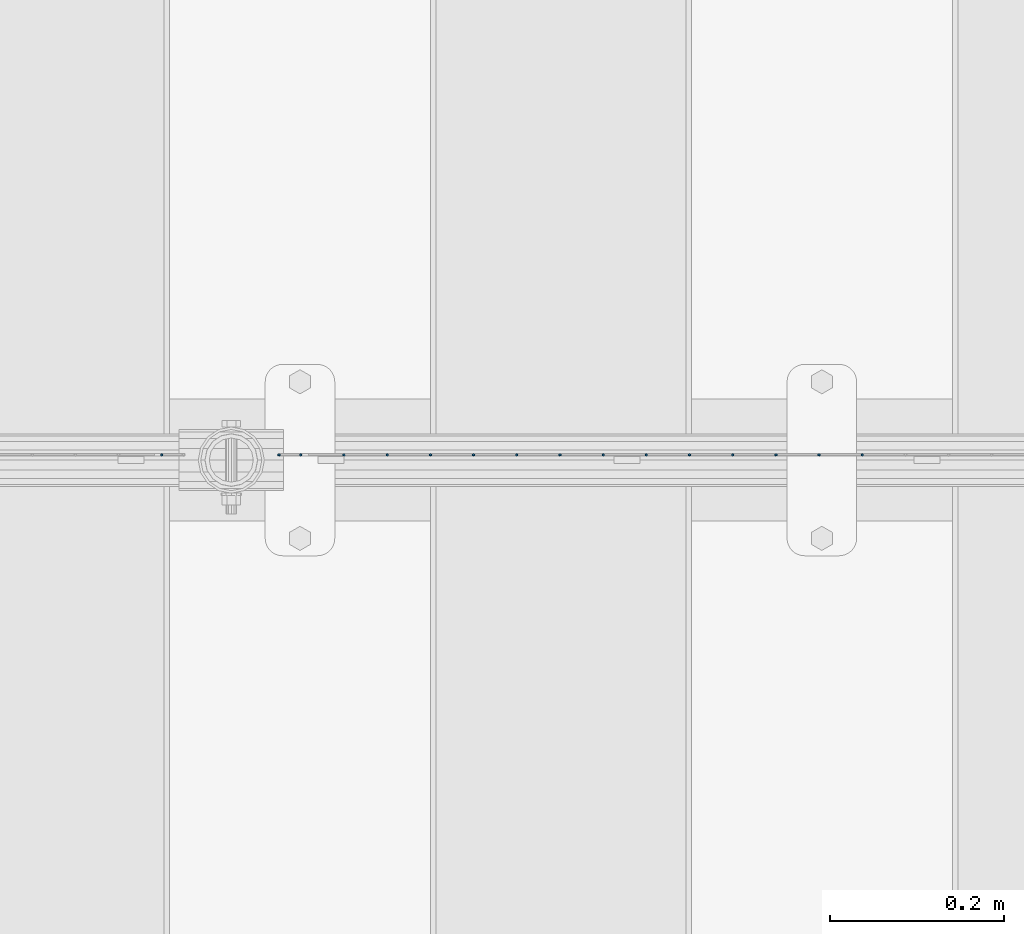
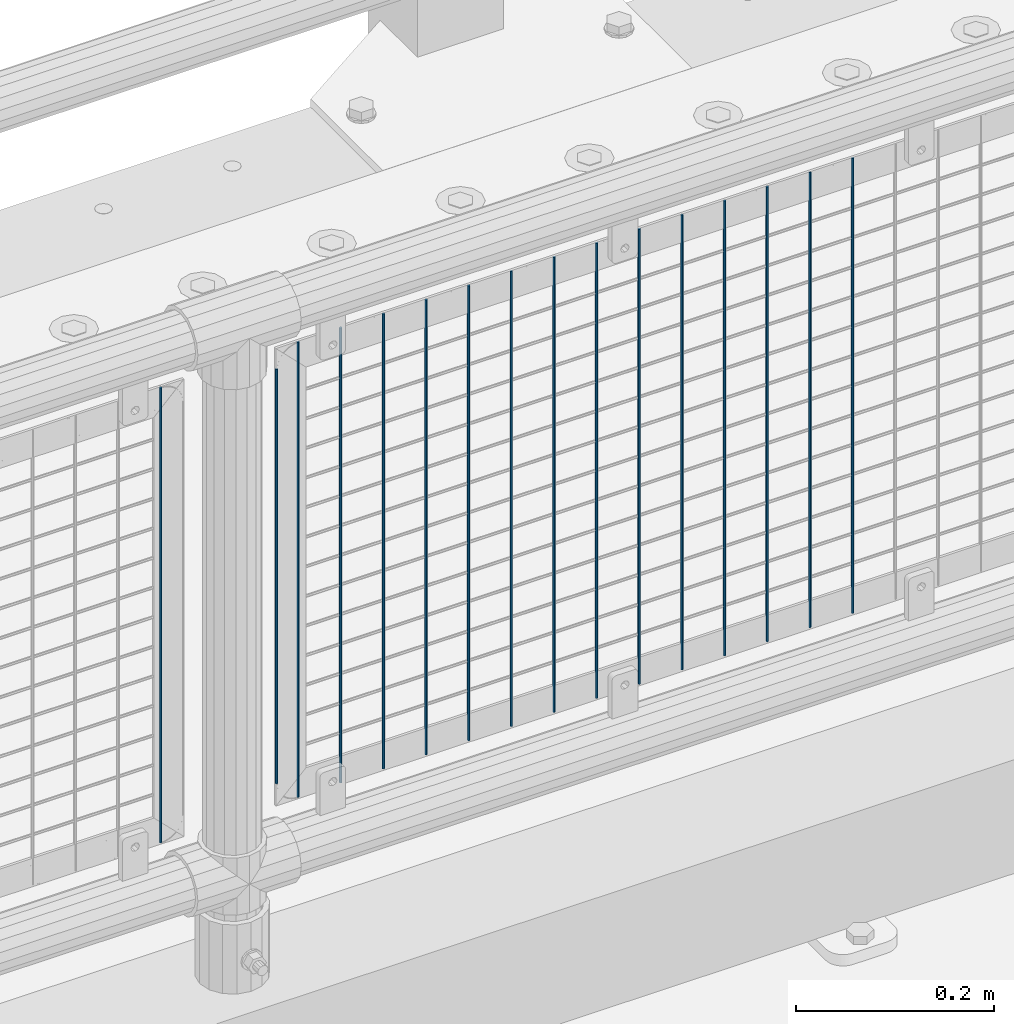
# One storey, part 90 of 247: 16 columns.
"""IFC2X3 building model written with IfcOpenShell, lengths in millimetres."""

from ifc_helpers import new_model, si_unit, frame, origin_with_axes, place, context, subcontext, project, spatial, faceted_brep, material, type_object, element, save


model = new_model("IFC2X3")

# Units and contexts
model_context = context("Model", 3, precision=1e-05, world=origin_with_axes())
body_context = subcontext(model_context, "Body", "Model", "MODEL_VIEW")
ifc_project = project(units=[si_unit("LENGTHUNIT", "METRE", prefix="MILLI"), si_unit("AREAUNIT", "SQUARE_METRE"), si_unit("VOLUMEUNIT", "CUBIC_METRE"), si_unit("MASSUNIT", "GRAM", prefix="KILO"), si_unit("TIMEUNIT", "SECOND"), si_unit("PLANEANGLEUNIT", "RADIAN"), si_unit("SOLIDANGLEUNIT", "STERADIAN"), si_unit("THERMODYNAMICTEMPERATUREUNIT", "DEGREE_CELSIUS"), si_unit("LUMINOUSINTENSITYUNIT", "LUMEN")], contexts=[model_context])

# Site, building, storey
site_placement = place(None, origin_with_axes())
site = spatial("IfcSite", under=ifc_project, at=site_placement, CompositionType="ELEMENT")
building_placement = place(site_placement, origin_with_axes())
building = spatial("IfcBuilding", under=site, at=building_placement, Name="Standard", CompositionType="ELEMENT")
storey_placement = place(building_placement, origin_with_axes())
storey = spatial("IfcBuildingStorey", under=building, at=storey_placement, Name="Undefined", CompositionType="ELEMENT", Elevation=0.0)

# Columns
ifc_material = material(Name="Misc_Undefined")
column_type = type_object("IfcColumnType", Name="D3", PredefinedType="NOTDEFINED")
for number, where, z_axis, x_axis in (
    (1, (10946.515, 7670.50000000001, 353.020000000004), (-1.0, 0.0, 0.0), (0.0, 0.0, 1.0)),
    (2, (10896.86, 7670.50000000001, 353.020000000004), (-1.0, 0.0, 0.0), (0.0, 0.0, 1.0)),
    (3, (10847.205, 7670.50000000001, 353.020000000004), (-1.0, 0.0, 0.0), (0.0, 0.0, 1.0)),
    (4, (10797.55, 7670.50000000001, 353.020000000004), (-1.0, 0.0, 0.0), (0.0, 0.0, 1.0)),
    (5, (10747.895, 7670.50000000001, 353.020000000004), (-1.0, 0.0, 0.0), (0.0, 0.0, 1.0)),
    (6, (10698.24, 7670.50000000001, 353.020000000004), (-1.0, 0.0, 0.0), (0.0, 0.0, 1.0)),
    (7, (10648.585, 7670.50000000001, 353.020000000004), (-1.0, 0.0, 0.0), (0.0, 0.0, 1.0)),
    (8, (10598.93, 7670.50000000001, 353.020000000004), (-1.0, 0.0, 0.0), (0.0, 0.0, 1.0)),
    (9, (10549.275, 7670.50000000001, 353.020000000004), (-1.0, 0.0, 0.0), (0.0, 0.0, 1.0)),
    (10, (10499.62, 7670.50000000001, 353.020000000004), (-1.0, 0.0, 0.0), (0.0, 0.0, 1.0)),
    (11, (10449.965, 7670.5, 353.020000000004), (-1.0, 0.0, 0.0), (0.0, 0.0, 1.0)),
    (12, (10400.3103448276, 7670.5, 353.020000000004), (-1.0, 0.0, 0.0), (0.0, 0.0, 1.0)),
    (13, (10350.6551724138, 7670.5, 353.020000000004), (-0.999999999962839, 0.0, 8.62099999968473e-06), (8.62099999949798e-06, 0.0, 0.999999999962839)),
):
    element("IfcColumn", number, at=place(storey_placement, frame(where, z_axis=z_axis, x_axis=x_axis)), inside=storey, type_object=column_type, material=ifc_material, ObjectType="D3", context=body_context, shape_type="Brep", body=[
        faceted_brep([(1.81898940354586e-12, -1.5, -5.6843418860808e-14), (0.0, -0.75, -1.29903810567703), (560.0, -0.75, -1.29903810567703), (560.0, -1.5, 0.0), (0.0, 0.75, -1.29903810567703), (560.0, 0.75, -1.29903810567703), (1.81898940354586e-12, 1.5, -5.6843418860808e-14), (560.0, 1.5, 0.0), (0.0, 0.75, 1.29903810567703), (560.0, 0.75, 1.29903810567703), (0.0, -0.75, 1.29903810567703), (560.0, -0.75, 1.29903810567703)], [[[0, 1, 2, 3]], [[1, 4, 5, 2]], [[4, 6, 7, 5]], [[6, 8, 9, 7]], [[8, 10, 11, 9]], [[10, 0, 3, 11]], [[5, 7, 9, 11, 3, 2]], [[10, 8, 6, 4, 1, 0]]]),
    ])
column_placement = place(storey_placement, frame((10276.0, 7670.5, 378.020000000004), z_axis=(-1.0, 0.0, 0.0), x_axis=(0.0, 0.0, 1.0)))
element("IfcColumn", 14, at=column_placement, inside=storey, type_object=column_type, material=ifc_material, ObjectType="D3", context=body_context, shape_type="Brep", body=[
    faceted_brep([(1.81898940354586e-12, -1.5, -5.6843418860808e-14), (0.0, -0.75, -1.29903810567703), (510.0, -0.75, -1.29903810567703), (510.0, -1.5, 0.0), (0.0, 0.75, -1.29903810567703), (510.0, 0.75, -1.29903810567703), (1.81898940354586e-12, 1.5, -5.6843418860808e-14), (510.0, 1.5, 0.0), (0.0, 0.75, 1.29903810567703), (510.0, 0.75, 1.29903810567703), (0.0, -0.75, 1.29903810567703), (510.0, -0.75, 1.29903810567703)], [[[0, 1, 2, 3]], [[1, 4, 5, 2]], [[4, 6, 7, 5]], [[6, 8, 9, 7]], [[8, 10, 11, 9]], [[10, 0, 3, 11]], [[5, 7, 9, 11, 3, 2]], [[10, 8, 6, 4, 1, 0]]]),
])
for number, where, z_axis, x_axis in (
    (15, (10301.0, 7670.5, 353.020000000004), (-1.0, 0.0, 0.0), (0.0, 0.0, 1.0)),
    (16, (10140.995, 7670.50000000001, 353.020000000003), (-1.0, 0.0, 0.0), (0.0, 0.0, 1.0)),
):
    element("IfcColumn", number, at=place(storey_placement, frame(where, z_axis=z_axis, x_axis=x_axis)), inside=storey, type_object=column_type, material=ifc_material, ObjectType="D3", context=body_context, shape_type="Brep", body=[
        faceted_brep([(1.81898940354586e-12, -1.5, -5.6843418860808e-14), (0.0, -0.75, -1.29903810567703), (560.0, -0.75, -1.29903810567703), (560.0, -1.5, 0.0), (0.0, 0.75, -1.29903810567703), (560.0, 0.75, -1.29903810567703), (1.81898940354586e-12, 1.5, -5.6843418860808e-14), (560.0, 1.5, 0.0), (0.0, 0.75, 1.29903810567703), (560.0, 0.75, 1.29903810567703), (0.0, -0.75, 1.29903810567703), (560.0, -0.75, 1.29903810567703)], [[[0, 1, 2, 3]], [[1, 4, 5, 2]], [[4, 6, 7, 5]], [[6, 8, 9, 7]], [[8, 10, 11, 9]], [[10, 0, 3, 11]], [[5, 7, 9, 11, 3, 2]], [[10, 8, 6, 4, 1, 0]]]),
    ])

save(model, "model.ifc")
